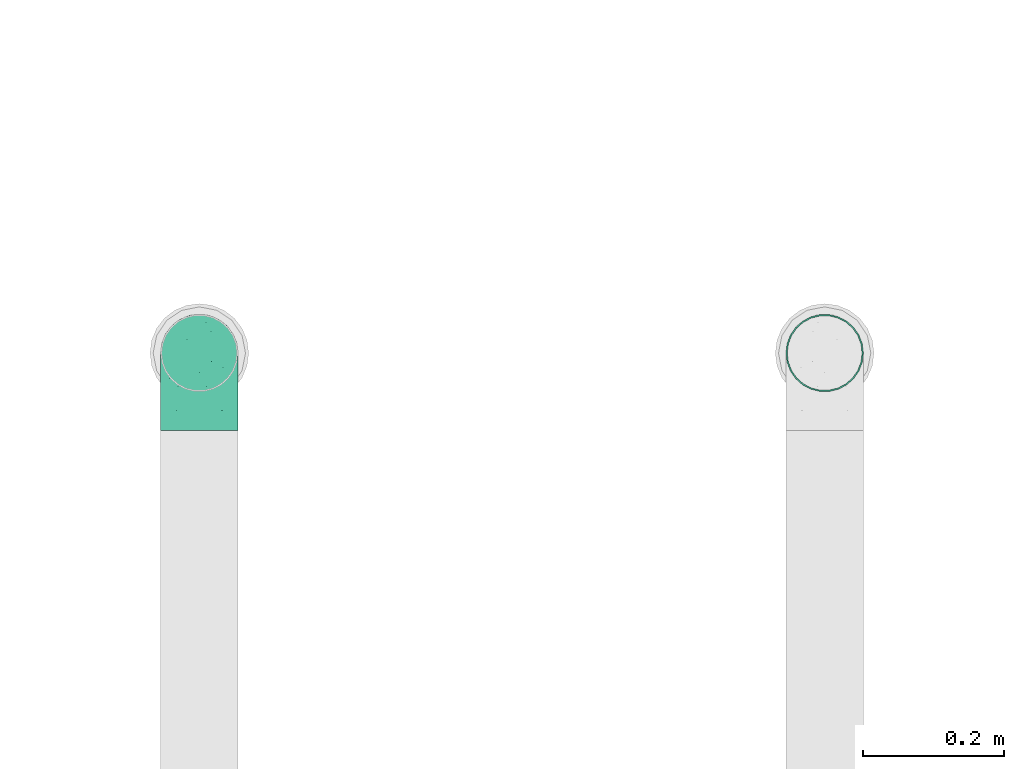
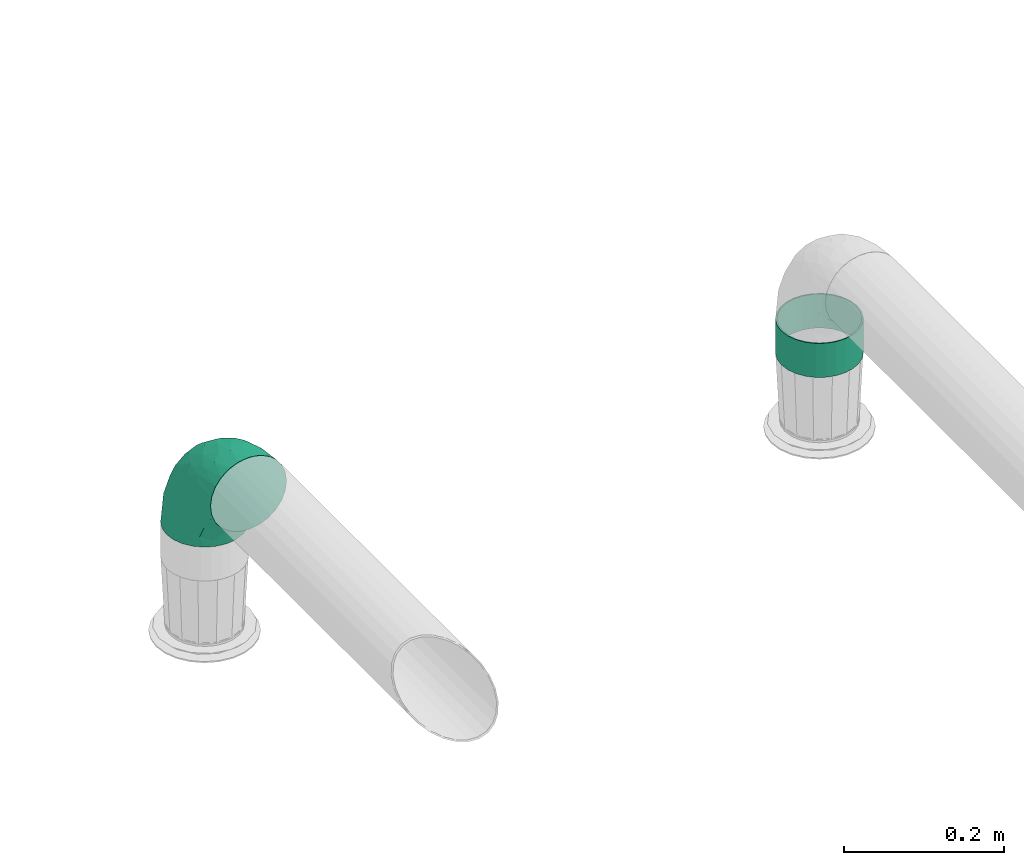
# One storey, part 30 of 123: 1 flow fitting, 1 flow segment.
"""IFC2X3 building model written with IfcOpenShell, lengths in millimetres."""

from ifc_helpers import new_model, entity, si_unit, converted_unit, derived_unit, direction, frame, origin_with_axes, origin_2d_with_axis, place, context, subcontext, project, spatial, hollow_circle, extrude, open_shell, surface_model, source, transform, mapped, material, layer, layer_set, layer_usage, type_object, element, save


model = new_model("IFC2X3")

# Units and contexts
model_context = context("Model", 3, precision=1e-05, world=origin_with_axes(), true_north=direction((0.0, 1.0)))
body_context = subcontext(model_context, "Body", "Model", "MODEL_VIEW")
ifc_project = project(units=[si_unit("AREAUNIT", "SQUARE_METRE"), si_unit("VOLUMEUNIT", "CUBIC_METRE", prefix="DECI"), si_unit("TIMEUNIT", "SECOND"), si_unit("THERMODYNAMICTEMPERATUREUNIT", "DEGREE_CELSIUS"), si_unit("PRESSUREUNIT", "PASCAL"), si_unit("MASSUNIT", "GRAM", prefix="KILO"), si_unit("LENGTHUNIT", "METRE", prefix="MILLI"), si_unit("POWERUNIT", "WATT"), si_unit("ELECTRICCURRENTUNIT", "AMPERE"), si_unit("ELECTRICVOLTAGEUNIT", "VOLT"), derived_unit("VOLUMETRICFLOWRATEUNIT", [(si_unit("VOLUMEUNIT", "CUBIC_METRE", prefix="DECI"), 1), (si_unit("TIMEUNIT", "SECOND"), -1)]), derived_unit("LINEARVELOCITYUNIT", [(si_unit("LENGTHUNIT", "METRE"), 1), (si_unit("TIMEUNIT", "SECOND"), -1)]), derived_unit("MASSDENSITYUNIT", [(si_unit("MASSUNIT", "GRAM", prefix="KILO"), 1), (si_unit("VOLUMEUNIT", "CUBIC_METRE"), -1)]), converted_unit("PLANEANGLEUNIT", "DEGREE", entity("IfcRatioMeasure", 0.01745), si_unit("PLANEANGLEUNIT", "RADIAN"), dimensions=[0, 0, 0, 0, 0, 0, 0])], contexts=[model_context])

# Site, building, storey
site_placement = place(None, origin_with_axes())
site = spatial("IfcSite", under=ifc_project, at=site_placement, CompositionType="ELEMENT")
building_placement = place(site_placement, origin_with_axes())
building = spatial("IfcBuilding", under=site, at=building_placement, Name="mc-building", CompositionType="ELEMENT")
storey_placement = place(building_placement, origin_with_axes())
storey = spatial("IfcBuildingStorey", under=building, at=storey_placement, Name="1. Korrus", CompositionType="ELEMENT", Elevation=0.0)

# Flow segment
ifc_material = material(Name="FZ1")
ifc_layer = layer(ifc_material, 0.0)
ifc_layer_set = layer_set([ifc_layer], Name="FZ1")
ifc_layer_usage = layer_usage(ifc_layer_set, "AXIS1", "POSITIVE", 0.0)
duct_segment_type = type_object("IfcDuctSegmentType", PredefinedType="RIGIDSEGMENT")
shared_shape_1 = source(origin_with_axes(), body_context, "Body", "SweptSolid", [
    extrude(hollow_circle(Radius=55.0, WallThickness=2.0, at=origin_2d_with_axis()), frame((0.0, 0.0, 0.0), z_axis=(1.0, 0.0, 0.0), x_axis=(0.0, 1.0, 0.0)), (0.0, 0.0, 1.0), 51.9),
])
flow_segment_placement = place(storey_placement, frame((9245.0, 4715.81442, 2355.0), z_axis=(0.0, 1.0, 0.0), x_axis=(0.0, 0.0, -1.0)))
element("IfcFlowSegment", 1, at=flow_segment_placement, inside=storey, type_object=duct_segment_type, material=ifc_layer_usage, context=body_context, shape_type="MappedRepresentation", body=[
    mapped(shared_shape_1, transform((0.0, 0.0, 0.0), scale=1.0)),
])

# Flow fitting
duct_fitting_type = type_object("IfcDuctFittingType", Name="BU", PredefinedType="BEND")
shared_shape_2 = source(origin_with_axes(), body_context, "Body", "SurfaceModel", [
    surface_model("IfcShellBasedSurfaceModel", [(-110.0, -38.89087, -38.89087), (-110.0, -55.0, 0.0), (-110.0, -27.5, -47.63139), (-110.0, -53.12592, -14.23505), (-110.0, -47.63139, -27.5), (-110.0, 47.63139, -27.5), (-110.0, 53.12592, 14.23505), (-110.0, 53.12592, -14.23505), (-110.0, -14.23505, -53.12592), (-110.0, 0.0, -55.0), (-110.0, 38.89087, -38.89087), (-110.0, 27.5, -47.63139), (-110.0, 14.23505, -53.12592), (-110.0, 55.0, 0.0), (-110.0, -53.12592, 14.23505), (-110.0, -47.63139, 27.5), (-110.0, -38.89087, 38.89087), (-110.0, 0.0, 55.0), (-110.0, -27.5, 47.63139), (-110.0, -14.23505, 53.12592), (-110.0, 38.89087, 38.89087), (-110.0, 47.63139, 27.5), (-110.0, 27.5, 47.63139), (-110.0, 14.23505, 53.12592), (0.0, -110.0, -55.0), (14.23505, -110.0, -53.12592), (-14.23505, -110.0, -53.12592), (-53.12592, -110.0, 14.23505), (-27.5, -110.0, -47.63139), (-47.63139, -110.0, -27.5), (-38.89087, -110.0, -38.89087), (55.0, -110.0, 0.0), (53.12592, -110.0, 14.23505), (38.89087, -110.0, -38.89087), (27.5, -110.0, -47.63139), (53.12592, -110.0, -14.23505), (47.63139, -110.0, -27.5), (-53.12592, -110.0, -14.23505), (-47.63139, -110.0, 27.5), (-38.89087, -110.0, 38.89087), (14.23505, -110.0, 53.12592), (-27.5, -110.0, 47.63139), (-14.23505, -110.0, 53.12592), (47.63139, -110.0, 27.5), (38.89087, -110.0, 38.89087), (27.5, -110.0, 47.63139), (0.0, -110.0, 55.0), (-55.0, -110.0, 0.0), (-60.44912, -32.56953, 51.94617), (-76.6405, -38.18013, 45.55988), (-64.21732, -48.68956, 43.63444), (-90.15553, -11.94394, 54.09138), (-76.00813, -5.38378, 55.0), (-70.18771, -18.55163, 54.03432), (-78.5998, -26.77405, 50.81338), (-93.27622, -45.77614, 33.48188), (-75.55424, -54.2118, 32.41257), (-96.12334, -22.13664, 50.81337), (-32.04182, -59.64019, 52.24446), (-18.36258, -70.48427, 54.04484), (-21.00813, -45.34362, 55.0), (-63.60674, -66.07878, 29.97482), (-74.66383, -63.08407, 19.92123), (-63.88653, -74.77858, 17.99134), (-93.11138, -56.59448, 10.50359), (-99.597, -52.72185, 18.52927), (-98.21577, -57.34403, 0.0), (-53.42855, -92.60092, 21.04759), (-88.54852, -54.8376, 21.04759), (-5.38378, -76.00813, 55.0), (-11.86161, -90.23965, 54.10313), (-56.64619, -93.12774, 10.22088), (-57.34403, -98.21577, 0.0), (-44.60838, -44.60838, 52.13415), (-45.34362, -21.00813, 55.0), (-92.68484, -35.46673, 43.63443), (-22.25266, -95.40765, 50.81337), (-27.23711, -77.39884, 50.81337), (-43.70931, -69.58671, 44.47149), (-35.97783, -90.61597, 43.63443), (-58.67786, -84.31125, 16.04456), (-57.2828, -79.3123, 24.9774), (-82.93277, -60.36161, 12.91784), (-49.88337, -54.51816, 47.224), (-74.57753, -66.83759, 9.55742), (-45.35812, -94.97281, 33.48188), (-59.18663, -88.95241, 0.0), (-51.517, -78.6292, 33.48188), (-65.14788, -80.03077, 0.0), (-56.45322, -62.06476, 39.63545), (-88.95241, -59.18663, 0.0), (-80.03077, -65.14788, 0.0), (-71.10913, -71.10913, 0.0), (-94.9309, -45.36788, -33.48188), (-93.11358, -56.60141, -10.46614), (-99.64997, -52.79499, -18.30015), (-79.99933, -46.56772, -37.92748), (-90.20425, -36.08686, -43.63443), (-45.34362, -21.00813, -55.0), (-72.75364, -19.68651, -53.60527), (-76.00813, -5.38378, -55.0), (-21.00813, -45.34362, -55.0), (-5.38378, -76.00813, -55.0), (-21.91957, -65.12078, -53.85897), (-35.41876, -92.89265, -43.63443), (-91.10309, -11.02766, -54.21832), (-45.77614, -93.27622, -33.48188), (-90.50474, -23.21022, -50.81337), (-70.92854, -33.31794, -49.51754), (-78.52933, -63.35627, -11.73997), (-24.91508, -84.05606, -50.81337), (-88.78941, -54.74452, -21.04759), (-63.49062, -67.59111, -28.46929), (-73.36422, -62.46673, -22.94182), (-69.59921, -57.34866, -33.48187), (-56.59448, -93.11138, -10.50359), (-54.10679, -75.85581, -32.31867), (-54.8376, -88.54852, -21.04759), (-57.75956, -31.09612, -52.80882), (-52.72185, -99.597, -18.52927), (-12.62913, -89.46304, -53.99097), (-34.46825, -66.46123, -50.04329), (-43.9837, -43.9837, -52.42279), (-65.78527, -72.58348, -17.68796), (-57.47001, -51.99467, -44.91465), (-70.34468, -43.65295, -44.21951), (-60.72547, -82.29174, -12.88567), (-42.34915, -74.24548, -43.63444), (-57.25194, -63.5016, -38.08211), (-80.95344, -53.56991, -29.32027), (-52.32891, -4.55257, -54.0482), (14.95561, -36.05775, -42.26543), (14.88266, -20.92917, -33.7947), (32.52942, -47.13398, -30.48571), (19.3559, -65.35825, -48.00507), (30.24048, -70.09027, -41.7461), (-28.49299, 30.5778, -16.4009), (-47.13398, 32.52942, -30.48571), (-70.35075, 46.44478, -19.5952), (-22.4954, -22.4954, -53.25347), (-4.55257, -52.32891, -54.0482), (-75.47368, 11.22546, -52.60718), (-81.32209, 51.5606, -9.98467), (-70.09027, 30.24048, -41.7461), (-80.81763, 41.84862, -32.14655), (-9.15831, 10.852, -27.8997), (-36.05774, 14.95561, -42.26543), (-65.35825, 19.3559, -48.00507), (3.94376, -43.9333, -50.53315), (11.22546, -75.47368, -52.60718), (-43.9333, 3.94376, -50.53315), (-13.39742, -13.39743, -48.13058), (50.20582, -74.51695, -9.9731), (41.8609, -47.82256, -9.92641), (49.37776, -67.29486, 0.0), (18.93131, -11.7156, -17.56239), (-1.23348, 12.25375, -12.18106), (-27.5, 32.89419, 0.0), (41.84862, -80.81763, -32.14655), (46.44478, -70.35075, -19.5952), (35.70604, -41.31408, -20.38235), (6.67262, 6.67262, 0.0), (32.89419, -27.5, 0.0), (-50.36265, 42.95545, -9.51562), (-67.29486, 49.37776, 0.0), (-5.47251, -5.47251, -39.92906), (-70.35075, 46.44478, 19.5952), (-74.51695, 50.20582, 9.9731), (-47.13398, 32.52942, 30.48571), (-41.31407, 35.70604, 20.38235), (-80.81763, 41.84862, 32.14655), (11.22546, -75.47368, 52.60718), (-4.55257, -52.32891, 54.0482), (-36.05774, 14.95561, 42.26543), (-65.35825, 19.3559, 48.00507), (-43.9333, 3.94376, 50.53315), (-70.09027, 30.24048, 41.7461), (-11.7156, 18.93131, 17.56239), (12.25375, -1.23348, 12.18106), (30.5778, -28.49299, 16.4009), (42.95545, -50.36265, 9.51562), (51.5606, -81.32209, 9.98467), (-52.32891, -4.55257, 54.0482), (-75.47368, 11.22546, 52.60718), (-13.39742, -13.39743, 48.13058), (-22.4954, -22.4954, 53.25347), (3.94376, -43.9333, 50.53315), (-20.92916, 14.88266, 33.79469), (10.852, -9.15831, 27.8997), (-47.82256, 41.8609, 9.92641), (32.52942, -47.13398, 30.48571), (46.44478, -70.35075, 19.5952), (41.84862, -80.81763, 32.14655), (14.95561, -36.05775, 42.26543), (19.3559, -65.35825, 48.00507), (30.24048, -70.09027, 41.7461), (-5.47251, -5.47251, 39.92906)], [open_shell([[[0, 1, 2]], [[3, 1, 4]], [[5, 6, 7]], [[8, 1, 9]], [[2, 1, 8]], [[4, 1, 0]], [[10, 9, 6]], [[9, 10, 11]], [[11, 12, 9]], [[6, 5, 10]], [[7, 6, 13]], [[14, 15, 9]], [[9, 15, 16]], [[17, 16, 18]], [[9, 16, 17]], [[19, 17, 18]], [[9, 20, 21]], [[6, 9, 21]], [[9, 22, 20]], [[23, 22, 9]], [[17, 23, 9]], [[9, 1, 14]], [[24, 25, 26]], [[26, 27, 28]], [[29, 30, 27]], [[28, 27, 30]], [[26, 31, 32]], [[33, 31, 34]], [[25, 34, 31]], [[35, 31, 36]], [[33, 36, 31]], [[31, 26, 25]], [[29, 27, 37]], [[38, 27, 26]], [[39, 38, 26]], [[40, 41, 26]], [[41, 39, 26]], [[40, 42, 41]], [[43, 44, 26]], [[43, 26, 32]], [[44, 45, 26]], [[26, 45, 40]], [[40, 46, 42]], [[47, 37, 27]], [[48, 49, 50]], [[51, 52, 17]], [[48, 53, 54]], [[49, 55, 56]], [[16, 15, 55]], [[18, 57, 19]], [[58, 59, 60]], [[61, 62, 63]], [[64, 65, 14]], [[53, 51, 54]], [[66, 64, 14]], [[27, 38, 67]], [[65, 68, 55]], [[68, 65, 64]], [[69, 59, 70]], [[71, 72, 27]], [[73, 60, 74]], [[55, 49, 75]], [[42, 70, 76]], [[51, 57, 54]], [[77, 78, 79]], [[42, 76, 41]], [[46, 70, 42]], [[55, 68, 56]], [[75, 18, 16]], [[77, 79, 76]], [[80, 67, 81]], [[68, 82, 62]], [[83, 78, 58]], [[82, 84, 62]], [[39, 79, 85]], [[71, 67, 80]], [[72, 71, 86]], [[67, 85, 87]], [[88, 80, 63]], [[39, 41, 79]], [[87, 79, 78]], [[55, 75, 16]], [[50, 89, 83]], [[38, 39, 85]], [[56, 68, 62]], [[61, 87, 89]], [[48, 50, 83]], [[18, 75, 57]], [[54, 75, 49]], [[38, 85, 67]], [[85, 79, 87]], [[56, 62, 61]], [[50, 56, 89]], [[87, 61, 81]], [[90, 64, 66]], [[14, 1, 66]], [[91, 92, 84]], [[82, 90, 91]], [[90, 82, 64]], [[62, 84, 63]], [[84, 82, 91]], [[64, 82, 68]], [[65, 15, 14]], [[15, 65, 55]], [[72, 47, 27]], [[86, 71, 80]], [[67, 71, 27]], [[88, 63, 92]], [[63, 80, 81]], [[63, 81, 61]], [[87, 81, 67]], [[41, 76, 79]], [[70, 59, 77]], [[76, 70, 77]], [[69, 70, 46]], [[77, 59, 58]], [[59, 69, 60]], [[77, 58, 78]], [[73, 58, 60]], [[19, 57, 51]], [[54, 57, 75]], [[19, 51, 17]], [[53, 52, 51]], [[53, 74, 52]], [[73, 74, 48]], [[53, 48, 74]], [[83, 73, 48]], [[73, 83, 58]], [[78, 83, 89]], [[78, 89, 87]], [[61, 89, 56]], [[54, 49, 48]], [[50, 49, 56]], [[88, 86, 80]], [[63, 84, 92]], [[93, 4, 0]], [[66, 94, 90]], [[95, 94, 3]], [[96, 93, 97]], [[98, 99, 100]], [[0, 2, 97]], [[101, 102, 103]], [[104, 28, 30]], [[9, 105, 8]], [[30, 106, 104]], [[107, 105, 99]], [[97, 107, 108]], [[94, 109, 90]], [[2, 8, 107]], [[94, 66, 3]], [[110, 26, 28]], [[94, 111, 109]], [[112, 113, 114]], [[72, 115, 37]], [[116, 106, 117]], [[98, 118, 99]], [[119, 115, 117]], [[115, 119, 37]], [[110, 120, 26]], [[103, 110, 121]], [[117, 106, 119]], [[120, 110, 103]], [[98, 101, 122]], [[117, 123, 116]], [[108, 124, 125]], [[126, 117, 115]], [[30, 29, 106]], [[120, 102, 24]], [[110, 104, 127]], [[97, 125, 96]], [[118, 122, 124]], [[124, 127, 128]], [[93, 0, 97]], [[86, 126, 115]], [[127, 106, 116]], [[129, 113, 111]], [[4, 93, 95]], [[114, 129, 96]], [[28, 104, 110]], [[127, 104, 106]], [[2, 107, 97]], [[108, 107, 99]], [[118, 108, 99]], [[100, 99, 105]], [[128, 112, 114]], [[127, 124, 121]], [[66, 1, 3]], [[91, 90, 109]], [[95, 111, 94]], [[109, 123, 92]], [[114, 113, 129]], [[111, 95, 93]], [[95, 3, 4]], [[86, 115, 72]], [[37, 47, 72]], [[88, 92, 123]], [[123, 117, 126]], [[126, 88, 123]], [[88, 126, 86]], [[119, 29, 37]], [[29, 119, 106]], [[111, 93, 129]], [[124, 114, 125]], [[100, 105, 9]], [[8, 105, 107]], [[108, 118, 124]], [[122, 118, 98]], [[96, 129, 93]], [[109, 111, 113]], [[113, 123, 109]], [[116, 123, 112]], [[113, 112, 123]], [[116, 112, 128]], [[116, 128, 127]], [[124, 128, 114]], [[103, 122, 101]], [[127, 121, 110]], [[121, 122, 103]], [[122, 121, 124]], [[26, 120, 24]], [[102, 120, 103]], [[108, 125, 97]], [[109, 92, 91]], [[96, 125, 114]], [[100, 130, 98]], [[131, 132, 133]], [[134, 135, 34]], [[136, 137, 138]], [[101, 139, 140]], [[9, 141, 100]], [[138, 7, 142]], [[137, 143, 144]], [[142, 7, 13]], [[145, 146, 137]], [[146, 147, 143]], [[5, 138, 144]], [[7, 138, 5]], [[5, 144, 10]], [[140, 148, 149]], [[143, 11, 10]], [[147, 12, 11]], [[100, 141, 130]], [[98, 139, 101]], [[148, 134, 149]], [[139, 150, 151]], [[152, 153, 154]], [[150, 139, 130]], [[25, 24, 149]], [[141, 12, 147]], [[132, 145, 155]], [[156, 136, 157]], [[158, 33, 135]], [[148, 139, 151]], [[36, 33, 158]], [[34, 135, 33]], [[159, 160, 153]], [[160, 159, 133]], [[137, 146, 143]], [[152, 154, 31]], [[137, 136, 145]], [[161, 162, 155]], [[133, 159, 158]], [[134, 148, 131]], [[163, 164, 157]], [[163, 142, 164]], [[102, 101, 140]], [[162, 154, 153]], [[159, 35, 36]], [[155, 156, 161]], [[131, 165, 132]], [[155, 145, 156]], [[98, 130, 139]], [[150, 130, 141]], [[147, 150, 141]], [[9, 12, 141]], [[149, 24, 102]], [[148, 140, 139]], [[140, 149, 102]], [[34, 25, 134]], [[146, 151, 150]], [[143, 147, 11]], [[147, 146, 150]], [[145, 165, 146]], [[25, 149, 134]], [[135, 134, 131]], [[135, 131, 133]], [[151, 165, 131]], [[148, 151, 131]], [[165, 151, 146]], [[160, 133, 132]], [[132, 165, 145]], [[36, 158, 159]], [[133, 158, 135]], [[10, 144, 143]], [[137, 144, 138]], [[162, 153, 155]], [[159, 153, 152]], [[160, 155, 153]], [[155, 160, 132]], [[152, 35, 159]], [[35, 152, 31]], [[136, 138, 163]], [[164, 142, 13]], [[142, 163, 138]], [[136, 163, 157]], [[161, 156, 157]], [[136, 156, 145]], [[166, 6, 21]], [[167, 164, 13]], [[166, 168, 169]], [[170, 168, 166]], [[69, 171, 172]], [[173, 174, 175]], [[174, 176, 22]], [[161, 157, 177]], [[170, 20, 176]], [[21, 20, 170]], [[178, 179, 162]], [[180, 181, 154]], [[182, 175, 183]], [[183, 23, 17]], [[184, 185, 186]], [[74, 185, 182]], [[52, 74, 182]], [[187, 188, 177]], [[166, 169, 189]], [[190, 179, 188]], [[22, 176, 20]], [[180, 154, 162]], [[32, 191, 43]], [[192, 44, 43]], [[43, 191, 192]], [[32, 31, 181]], [[193, 194, 195]], [[194, 40, 45]], [[190, 193, 195]], [[45, 44, 195]], [[69, 46, 171]], [[74, 60, 185]], [[157, 164, 189]], [[167, 189, 164]], [[172, 60, 69]], [[185, 172, 186]], [[173, 187, 168]], [[191, 32, 181]], [[190, 195, 192]], [[179, 190, 191]], [[175, 174, 183]], [[171, 40, 194]], [[188, 193, 190]], [[175, 185, 184]], [[177, 178, 161]], [[173, 196, 187]], [[177, 188, 178]], [[60, 172, 185]], [[186, 172, 171]], [[194, 186, 171]], [[46, 40, 171]], [[183, 17, 52]], [[175, 182, 185]], [[182, 183, 52]], [[22, 23, 174]], [[193, 184, 186]], [[195, 194, 45]], [[194, 193, 186]], [[188, 196, 193]], [[23, 183, 174]], [[176, 174, 173]], [[176, 173, 168]], [[184, 196, 173]], [[175, 184, 173]], [[196, 184, 193]], [[169, 168, 187]], [[187, 196, 188]], [[21, 170, 166]], [[168, 170, 176]], [[44, 192, 195]], [[190, 192, 191]], [[157, 189, 177]], [[166, 189, 167]], [[169, 177, 189]], [[177, 169, 187]], [[167, 6, 166]], [[6, 167, 13]], [[179, 191, 180]], [[154, 181, 31]], [[181, 180, 191]], [[179, 180, 162]], [[161, 178, 162]], [[179, 178, 188]]])]),
])
flow_fitting_placement = place(storey_placement, frame((8357.82156, 4715.81442, 2465.0), z_axis=(-1.0, 0.0, 0.0), x_axis=(0.0, 0.0, 1.0)))
element("IfcFlowFitting", 2, at=flow_fitting_placement, inside=storey, type_object=duct_fitting_type, Name="BU", context=body_context, shape_type="MappedRepresentation", body=[
    mapped(shared_shape_2, transform((0.0, 0.0, 0.0), scale=1.0)),
])

save(model, "model.ifc")
